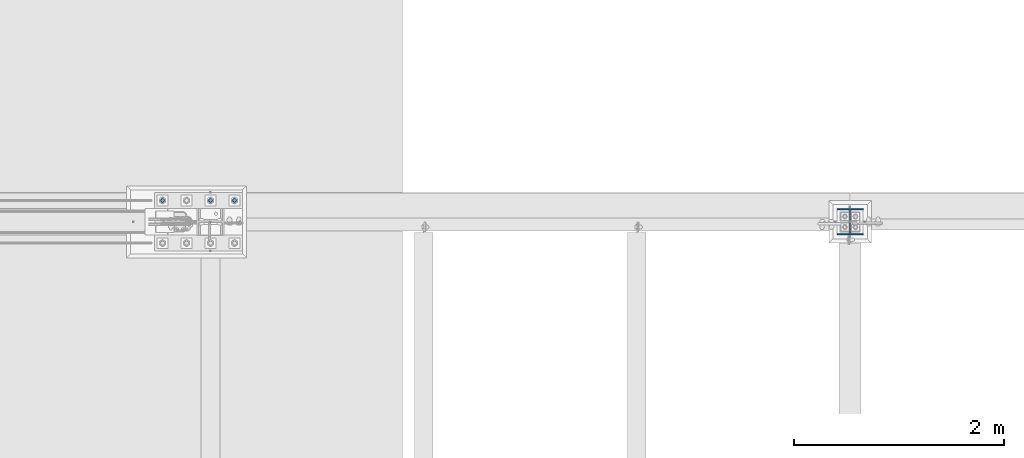
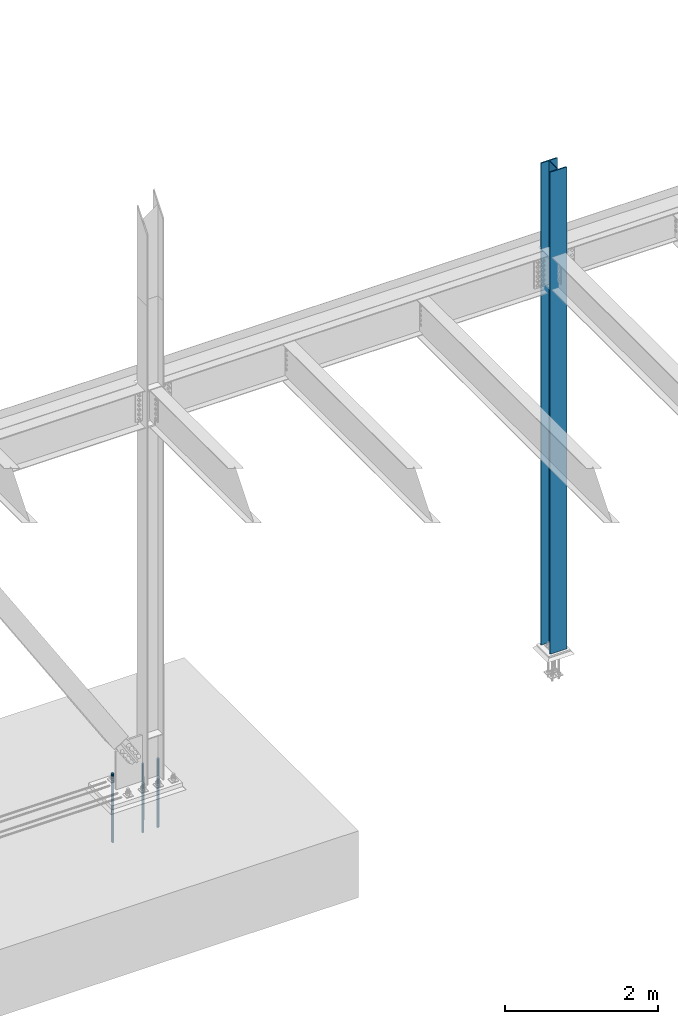
# One storey, part 1396 of 3843: 4 columns, 2 elements without a shape of their own.
"""IFC2X3 building model written with IfcOpenShell, lengths in millimetres."""

from ifc_helpers import new_model, si_unit, frame, origin_with_axes, place, context, subcontext, project, spatial, faceted_brep, material, type_object, element, aggregate, save


model = new_model("IFC2X3")

# Units and contexts
model_context = context("Model", 3, precision=1e-05, world=origin_with_axes())
body_context = subcontext(model_context, "Body", "Model", "MODEL_VIEW")
ifc_project = project(units=[si_unit("LENGTHUNIT", "METRE", prefix="MILLI"), si_unit("AREAUNIT", "SQUARE_METRE"), si_unit("VOLUMEUNIT", "CUBIC_METRE"), si_unit("MASSUNIT", "GRAM", prefix="KILO"), si_unit("TIMEUNIT", "SECOND"), si_unit("PLANEANGLEUNIT", "RADIAN"), si_unit("SOLIDANGLEUNIT", "STERADIAN"), si_unit("THERMODYNAMICTEMPERATUREUNIT", "DEGREE_CELSIUS"), si_unit("LUMINOUSINTENSITYUNIT", "LUMEN")], contexts=[model_context])

# Site, building, storey
site_placement = place(None, origin_with_axes())
site = spatial("IfcSite", under=ifc_project, at=site_placement, CompositionType="ELEMENT")
building_placement = place(site_placement, origin_with_axes())
building = spatial("IfcBuilding", under=site, at=building_placement, Name="Undefined", CompositionType="ELEMENT")
storey_placement = place(building_placement, origin_with_axes())
storey = spatial("IfcBuildingStorey", under=building, at=storey_placement, Name="Undefined", CompositionType="ELEMENT", Elevation=0.0)

# Assembly, columns
assembly_1_placement = place(storey_placement, origin_with_axes())
assembly_1 = element("IfcElementAssembly", 1, at=assembly_1_placement, inside=storey, Name="TEMPLATE", AssemblyPlace="NOTDEFINED", PredefinedType="RIGID_FRAME")
ifc_material_1 = material(Name="Undefined/F1554-GR.55")
column_type_1 = type_object("IfcColumnType", PredefinedType="NOTDEFINED")
column_1_placement = place(assembly_1_placement, frame((30708.6, 104762.3, 30022.8), z_axis=(-1.0, 0.0, 0.0), x_axis=(0.0, 0.0, -1.0)))
column_1 = element("IfcColumn", 2, at=column_1_placement, type_object=column_type_1, material=ifc_material_1, Name="ANCHOR_ROD", context=body_context, shape_type="Brep", body=[
    faceted_brep([(-209.549999999999, -16.0214699700155, 9.25), (-209.549999999999, -9.25, 16.0214699700118), (-209.549999999999, 0.0, 18.5), (-209.549999999999, 9.25, 16.0214699700118), (-209.549999999999, 16.0214699700155, 9.25), (-209.549999999999, 18.5, 0.0), (-209.549999999999, 16.0214699700155, -9.25), (-209.549999999999, 9.25, -16.0214699700118), (-209.549999999999, 0.0, -18.5), (-209.549999999999, -9.25, -16.0214699700118), (-209.549999999999, -16.0214699700155, -9.25), (-209.549999999999, -18.5, 0.0), (0.0, 18.5, 0.0), (0.0, 16.0214699700118, -9.25), (0.0, 9.25, -16.0214699700155), (0.0, 0.0, -18.5), (0.0, -9.25, -16.0214699700155), (0.0, -16.0214699700118, -9.25), (0.0, -18.5, 0.0), (0.0, -16.0214699700118, 9.25), (0.0, -9.25, 16.0214699700155), (0.0, 0.0, 18.5), (0.0, 9.25, 16.0214699700155), (0.0, 16.0214699700118, 9.25), (0.0, -16.4977839420972, 9.52500000000146), (0.0, -9.52500000000146, 16.4977839420972), (0.0, 0.0, 19.0499989999989), (0.0, 9.52500000000146, 16.4977839420972), (0.0, 16.4977839420972, 9.52500000000146), (0.0, 19.0500000000029, 0.0), (0.0, 16.4977839420972, -9.52500000000146), (0.0, 9.52500000000146, -16.4977839420972), (0.0, 0.0, -19.0499989999989), (0.0, -9.52500000000146, -16.4977839420972), (0.0, -16.4977839420972, -9.52500000000146), (0.0, -19.0500000000029, 0.0), (698.5, -19.0499999999993, 0.0), (698.5, -16.4977839420935, 9.52499999999418), (698.5, -9.52500000000146, 16.4977839420899), (698.5, 0.0, 19.0500000000029), (698.5, 9.52500000000146, 16.4977839420899), (698.5, 16.4977839420935, 9.52499999999418), (698.5, 19.0499999999993, 0.0), (698.5, 16.4977839420935, -9.52499999999418), (698.5, 9.52500000000146, -16.4977839420899), (698.5, 0.0, -19.0500000000029), (698.5, -9.52500000000146, -16.4977839420899), (698.5, -16.4977839420935, -9.52499999999418), (698.5, -9.25, 16.0214699700155), (698.5, 0.0, 18.5), (698.5, 9.25, 16.0214699700155), (698.5, 16.0214699700118, 9.25), (698.5, 18.5, 0.0), (698.5, 16.0214699700118, -9.25), (698.5, 9.25, -16.0214699700155), (698.5, 0.0, -18.5), (698.5, -9.25, -16.0214699700155), (698.5, -16.0214699700118, -9.25), (698.5, -18.5, 0.0), (698.5, -16.0214699700118, 9.25), (889.0, -9.25, -16.0214699700155), (889.0, 0.0, -18.5), (889.0, 9.25, -16.0214699700155), (889.0, 16.0214699700118, -9.25), (889.0, 18.5, 0.0), (889.0, 16.0214699700118, 9.25), (889.0, 9.25, 16.0214699700155), (889.0, 0.0, 18.5), (889.0, -9.25, 16.0214699700155), (889.0, -16.0214699700118, 9.25), (889.0, -18.5, 0.0), (889.0, -16.0214699700118, -9.25)], [[[0, 1, 2, 3, 4, 5, 6, 7, 8, 9, 10, 11]], [[6, 5, 12, 13]], [[7, 6, 13, 14]], [[8, 7, 14, 15]], [[9, 8, 15, 16]], [[10, 9, 16, 17]], [[11, 10, 17, 18]], [[0, 11, 18, 19]], [[1, 0, 19, 20]], [[2, 1, 20, 21]], [[3, 2, 21, 22]], [[4, 3, 22, 23]], [[5, 4, 23, 12]], [[24, 25, 26, 27, 28, 29, 30, 31, 32, 33, 34, 35], [22, 21, 20, 19, 18, 17, 16, 15, 14, 13, 12, 23]], [[24, 35, 36, 37]], [[25, 24, 37, 38]], [[26, 25, 38, 39]], [[27, 26, 39, 40]], [[28, 27, 40, 41]], [[29, 28, 41, 42]], [[30, 29, 42, 43]], [[31, 30, 43, 44]], [[32, 31, 44, 45]], [[33, 32, 45, 46]], [[34, 33, 46, 47]], [[35, 34, 47, 36]], [[46, 45, 44, 43, 42, 41, 40, 39, 38, 37, 36, 47], [48, 49, 50, 51, 52, 53, 54, 55, 56, 57, 58, 59]], [[60, 61, 62, 63, 64, 65, 66, 67, 68, 69, 70, 71]], [[68, 67, 49, 48]], [[69, 68, 48, 59]], [[70, 69, 59, 58]], [[71, 70, 58, 57]], [[60, 71, 57, 56]], [[61, 60, 56, 55]], [[62, 61, 55, 54]], [[63, 62, 54, 53]], [[64, 63, 53, 52]], [[65, 64, 52, 51]], [[66, 65, 51, 50]], [[67, 66, 50, 49]]]),
])
column_2_placement = place(assembly_1_placement, frame((30480.0, 104762.3, 30022.8), z_axis=(-1.0, 0.0, 0.0), x_axis=(0.0, 0.0, -1.0)))
column_2 = element("IfcColumn", 3, at=column_2_placement, type_object=column_type_1, material=ifc_material_1, Name="ANCHOR_ROD", context=body_context, shape_type="Brep", body=[
    faceted_brep([(-209.549999999999, -16.0214699700155, 9.25), (-209.549999999999, -9.25, 16.0214699700118), (-209.549999999999, 0.0, 18.5), (-209.549999999999, 9.25, 16.0214699700118), (-209.549999999999, 16.0214699700155, 9.25), (-209.549999999999, 18.5, 0.0), (-209.549999999999, 16.0214699700155, -9.25), (-209.549999999999, 9.25, -16.0214699700118), (-209.549999999999, 0.0, -18.5), (-209.549999999999, -9.25, -16.0214699700118), (-209.549999999999, -16.0214699700155, -9.25), (-209.549999999999, -18.5, 0.0), (0.0, 18.5, 0.0), (0.0, 16.0214699700118, -9.25), (0.0, 9.25, -16.0214699700155), (0.0, 0.0, -18.5), (0.0, -9.25, -16.0214699700155), (0.0, -16.0214699700118, -9.25), (0.0, -18.5, 0.0), (0.0, -16.0214699700118, 9.25), (0.0, -9.25, 16.0214699700155), (0.0, 0.0, 18.5), (0.0, 9.25, 16.0214699700155), (0.0, 16.0214699700118, 9.25), (0.0, -16.4977839420972, 9.52500000000146), (0.0, -9.52500000000146, 16.4977839420972), (0.0, 0.0, 19.0499989999989), (0.0, 9.52500000000146, 16.4977839420972), (0.0, 16.4977839420972, 9.52500000000146), (0.0, 19.0500000000029, 0.0), (0.0, 16.4977839420972, -9.52500000000146), (0.0, 9.52500000000146, -16.4977839420972), (0.0, 0.0, -19.0499989999989), (0.0, -9.52500000000146, -16.4977839420972), (0.0, -16.4977839420972, -9.52500000000146), (0.0, -19.0500000000029, 0.0), (698.5, -19.0499999999993, 0.0), (698.5, -16.4977839420935, 9.52499999999418), (698.5, -9.52500000000146, 16.4977839420899), (698.5, 0.0, 19.0500000000029), (698.5, 9.52500000000146, 16.4977839420899), (698.5, 16.4977839420935, 9.52499999999418), (698.5, 19.0499999999993, 0.0), (698.5, 16.4977839420935, -9.52499999999418), (698.5, 9.52500000000146, -16.4977839420899), (698.5, 0.0, -19.0500000000029), (698.5, -9.52500000000146, -16.4977839420899), (698.5, -16.4977839420935, -9.52499999999418), (698.5, -9.25, 16.0214699700155), (698.5, 0.0, 18.5), (698.5, 9.25, 16.0214699700155), (698.5, 16.0214699700118, 9.25), (698.5, 18.5, 0.0), (698.5, 16.0214699700118, -9.25), (698.5, 9.25, -16.0214699700155), (698.5, 0.0, -18.5), (698.5, -9.25, -16.0214699700155), (698.5, -16.0214699700118, -9.25), (698.5, -18.5, 0.0), (698.5, -16.0214699700118, 9.25), (889.0, -9.25, -16.0214699700155), (889.0, 0.0, -18.5), (889.0, 9.25, -16.0214699700155), (889.0, 16.0214699700118, -9.25), (889.0, 18.5, 0.0), (889.0, 16.0214699700118, 9.25), (889.0, 9.25, 16.0214699700155), (889.0, 0.0, 18.5), (889.0, -9.25, 16.0214699700155), (889.0, -16.0214699700118, 9.25), (889.0, -18.5, 0.0), (889.0, -16.0214699700118, -9.25)], [[[0, 1, 2, 3, 4, 5, 6, 7, 8, 9, 10, 11]], [[6, 5, 12, 13]], [[7, 6, 13, 14]], [[8, 7, 14, 15]], [[9, 8, 15, 16]], [[10, 9, 16, 17]], [[11, 10, 17, 18]], [[0, 11, 18, 19]], [[1, 0, 19, 20]], [[2, 1, 20, 21]], [[3, 2, 21, 22]], [[4, 3, 22, 23]], [[5, 4, 23, 12]], [[24, 25, 26, 27, 28, 29, 30, 31, 32, 33, 34, 35], [22, 21, 20, 19, 18, 17, 16, 15, 14, 13, 12, 23]], [[24, 35, 36, 37]], [[25, 24, 37, 38]], [[26, 25, 38, 39]], [[27, 26, 39, 40]], [[28, 27, 40, 41]], [[29, 28, 41, 42]], [[30, 29, 42, 43]], [[31, 30, 43, 44]], [[32, 31, 44, 45]], [[33, 32, 45, 46]], [[34, 33, 46, 47]], [[35, 34, 47, 36]], [[46, 45, 44, 43, 42, 41, 40, 39, 38, 37, 36, 47], [48, 49, 50, 51, 52, 53, 54, 55, 56, 57, 58, 59]], [[60, 61, 62, 63, 64, 65, 66, 67, 68, 69, 70, 71]], [[68, 67, 49, 48]], [[69, 68, 48, 59]], [[70, 69, 59, 58]], [[71, 70, 58, 57]], [[60, 71, 57, 56]], [[61, 60, 56, 55]], [[62, 61, 55, 54]], [[63, 62, 54, 53]], [[64, 63, 53, 52]], [[65, 64, 52, 51]], [[66, 65, 51, 50]], [[67, 66, 50, 49]]]),
])
column_3_placement = place(assembly_1_placement, frame((30022.8, 104762.3, 30022.8), z_axis=(-1.0, 0.0, 0.0), x_axis=(0.0, 0.0, -1.0)))
column_3 = element("IfcColumn", 4, at=column_3_placement, type_object=column_type_1, material=ifc_material_1, Name="ANCHOR_ROD", context=body_context, shape_type="Brep", body=[
    faceted_brep([(-209.549999999999, -16.0214699700155, 9.25), (-209.549999999999, -9.25, 16.0214699700118), (-209.549999999999, 0.0, 18.5), (-209.549999999999, 9.25, 16.0214699700118), (-209.549999999999, 16.0214699700155, 9.25), (-209.549999999999, 18.5, 0.0), (-209.549999999999, 16.0214699700155, -9.25), (-209.549999999999, 9.25, -16.0214699700118), (-209.549999999999, 0.0, -18.5), (-209.549999999999, -9.25, -16.0214699700118), (-209.549999999999, -16.0214699700155, -9.25), (-209.549999999999, -18.5, 0.0), (0.0, 18.5, 0.0), (0.0, 16.0214699700118, -9.25), (0.0, 9.25, -16.0214699700155), (0.0, 0.0, -18.5), (0.0, -9.25, -16.0214699700155), (0.0, -16.0214699700118, -9.25), (0.0, -18.5, 0.0), (0.0, -16.0214699700118, 9.25), (0.0, -9.25, 16.0214699700155), (0.0, 0.0, 18.5), (0.0, 9.25, 16.0214699700155), (0.0, 16.0214699700118, 9.25), (0.0, -16.4977839420972, 9.52500000000146), (0.0, -9.52500000000146, 16.4977839420972), (0.0, 0.0, 19.0499989999989), (0.0, 9.52500000000146, 16.4977839420972), (0.0, 16.4977839420972, 9.52500000000146), (0.0, 19.0500000000029, 0.0), (0.0, 16.4977839420972, -9.52500000000146), (0.0, 9.52500000000146, -16.4977839420972), (0.0, 0.0, -19.0499989999989), (0.0, -9.52500000000146, -16.4977839420972), (0.0, -16.4977839420972, -9.52500000000146), (0.0, -19.0500000000029, 0.0), (698.5, -19.0499999999993, 0.0), (698.5, -16.4977839420935, 9.52499999999418), (698.5, -9.52500000000146, 16.4977839420899), (698.5, 0.0, 19.0500000000029), (698.5, 9.52500000000146, 16.4977839420899), (698.5, 16.4977839420935, 9.52499999999418), (698.5, 19.0499999999993, 0.0), (698.5, 16.4977839420935, -9.52499999999418), (698.5, 9.52500000000146, -16.4977839420899), (698.5, 0.0, -19.0500000000029), (698.5, -9.52500000000146, -16.4977839420899), (698.5, -16.4977839420935, -9.52499999999418), (698.5, -9.25, 16.0214699700155), (698.5, 0.0, 18.5), (698.5, 9.25, 16.0214699700155), (698.5, 16.0214699700118, 9.25), (698.5, 18.5, 0.0), (698.5, 16.0214699700118, -9.25), (698.5, 9.25, -16.0214699700155), (698.5, 0.0, -18.5), (698.5, -9.25, -16.0214699700155), (698.5, -16.0214699700118, -9.25), (698.5, -18.5, 0.0), (698.5, -16.0214699700118, 9.25), (889.0, -9.25, -16.0214699700155), (889.0, 0.0, -18.5), (889.0, 9.25, -16.0214699700155), (889.0, 16.0214699700118, -9.25), (889.0, 18.5, 0.0), (889.0, 16.0214699700118, 9.25), (889.0, 9.25, 16.0214699700155), (889.0, 0.0, 18.5), (889.0, -9.25, 16.0214699700155), (889.0, -16.0214699700118, 9.25), (889.0, -18.5, 0.0), (889.0, -16.0214699700118, -9.25)], [[[0, 1, 2, 3, 4, 5, 6, 7, 8, 9, 10, 11]], [[6, 5, 12, 13]], [[7, 6, 13, 14]], [[8, 7, 14, 15]], [[9, 8, 15, 16]], [[10, 9, 16, 17]], [[11, 10, 17, 18]], [[0, 11, 18, 19]], [[1, 0, 19, 20]], [[2, 1, 20, 21]], [[3, 2, 21, 22]], [[4, 3, 22, 23]], [[5, 4, 23, 12]], [[24, 25, 26, 27, 28, 29, 30, 31, 32, 33, 34, 35], [22, 21, 20, 19, 18, 17, 16, 15, 14, 13, 12, 23]], [[24, 35, 36, 37]], [[25, 24, 37, 38]], [[26, 25, 38, 39]], [[27, 26, 39, 40]], [[28, 27, 40, 41]], [[29, 28, 41, 42]], [[30, 29, 42, 43]], [[31, 30, 43, 44]], [[32, 31, 44, 45]], [[33, 32, 45, 46]], [[34, 33, 46, 47]], [[35, 34, 47, 36]], [[46, 45, 44, 43, 42, 41, 40, 39, 38, 37, 36, 47], [48, 49, 50, 51, 52, 53, 54, 55, 56, 57, 58, 59]], [[60, 61, 62, 63, 64, 65, 66, 67, 68, 69, 70, 71]], [[68, 67, 49, 48]], [[69, 68, 48, 59]], [[70, 69, 59, 58]], [[71, 70, 58, 57]], [[60, 71, 57, 56]], [[61, 60, 56, 55]], [[62, 61, 55, 54]], [[63, 62, 54, 53]], [[64, 63, 53, 52]], [[65, 64, 52, 51]], [[66, 65, 51, 50]], [[67, 66, 50, 49]]]),
])
aggregate(assembly_1, [column_1, column_2, column_3])

# Assembly, column
assembly_2_placement = place(storey_placement, origin_with_axes())
assembly_2 = element("IfcElementAssembly", 5, at=assembly_2_placement, inside=storey, Name="COLUMN", AssemblyPlace="NOTDEFINED", PredefinedType="RIGID_FRAME")
ifc_material_2 = material(Name="STEEL/A992")
column_type_2 = type_object("IfcColumnType", Name="W10X49", PredefinedType="NOTDEFINED")
column_4_placement = place(assembly_2_placement, frame((36576.0, 104559.1, 30022.8), z_axis=(0.0, 1.0, 0.0), x_axis=(0.0, 0.0, 1.0)))
column_4 = element("IfcColumn", 6, at=column_4_placement, type_object=column_type_2, material=ifc_material_2, Name="COLUMN", ObjectType="W10X49", context=body_context, shape_type="Brep", body=[
    faceted_brep([(63.4999999999964, 127.0, -127.0), (63.4999999999964, 127.0, -112.712499999994), (7772.4, 127.0, -112.712499999994), (7772.4, 127.0, -127.0), (63.4999999999964, 3.96875, -112.7125), (7772.4, 3.96875, -112.712499999994), (63.4999999999964, 3.96875, 112.7125), (7772.4, 3.96875, 112.712499999994), (63.4999999999964, 127.0, 112.712499999994), (7772.4, 127.0, 112.712499999994), (63.4999999999964, 127.0, 127.0), (7772.4, 127.0, 127.0), (63.4999999999964, -127.0, 127.0), (7772.4, -127.0, 127.0), (63.4999999999964, -127.0, 112.712499999994), (7772.4, -127.0, 112.712499999994), (63.4999999999964, -3.96875, 112.7125), (7772.4, -3.96875, 112.712499999994), (63.4999999999964, -3.96875, -112.7125), (7772.4, -3.96875, -112.712499999994), (63.4999999999964, -127.0, -112.712499999994), (7772.4, -127.0, -112.712499999994), (63.4999999999964, -127.0, -127.0), (7772.4, -127.0, -127.0)], [[[0, 1, 2, 3]], [[1, 4, 5, 2]], [[4, 6, 7, 5]], [[6, 8, 9, 7]], [[8, 10, 11, 9]], [[10, 12, 13, 11]], [[12, 14, 15, 13]], [[14, 16, 17, 15]], [[16, 18, 19, 17]], [[18, 20, 21, 19]], [[20, 22, 23, 21]], [[22, 0, 3, 23]], [[5, 7, 9, 11, 13, 15, 17, 19, 21, 23, 3, 2]], [[22, 20, 18, 16, 14, 12, 10, 8, 6, 4, 1, 0]]]),
])
aggregate(assembly_2, [column_4])

save(model, "model.ifc")
